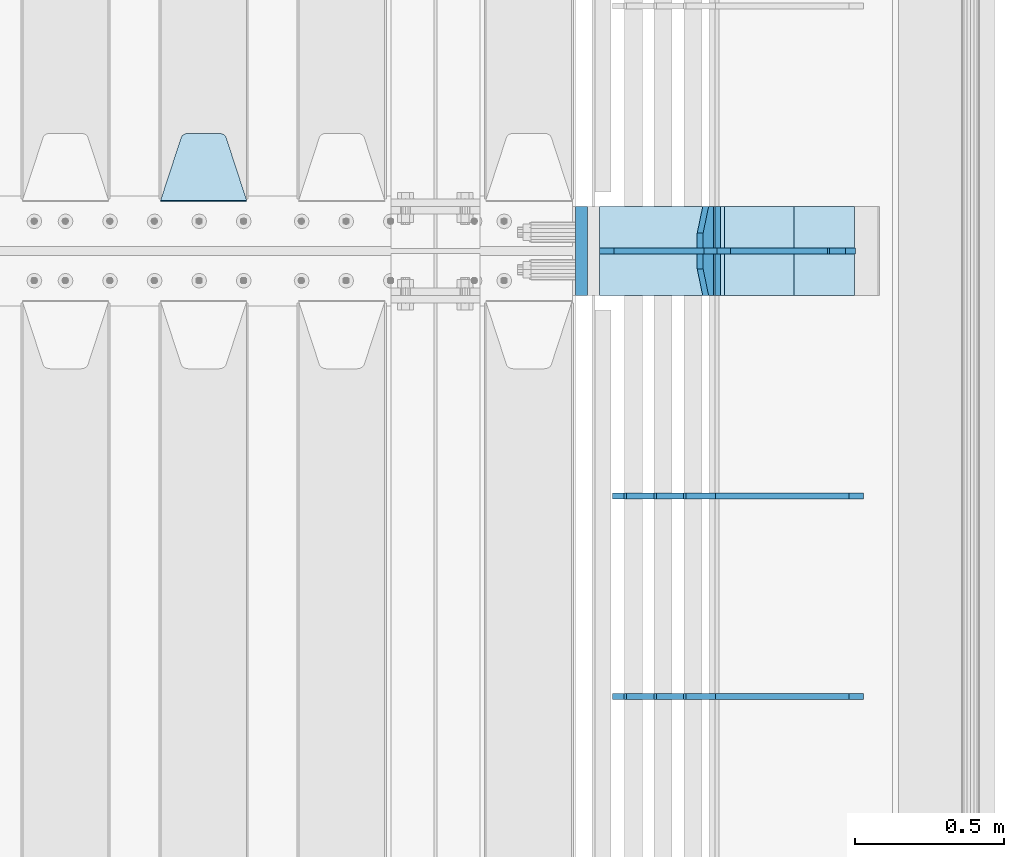
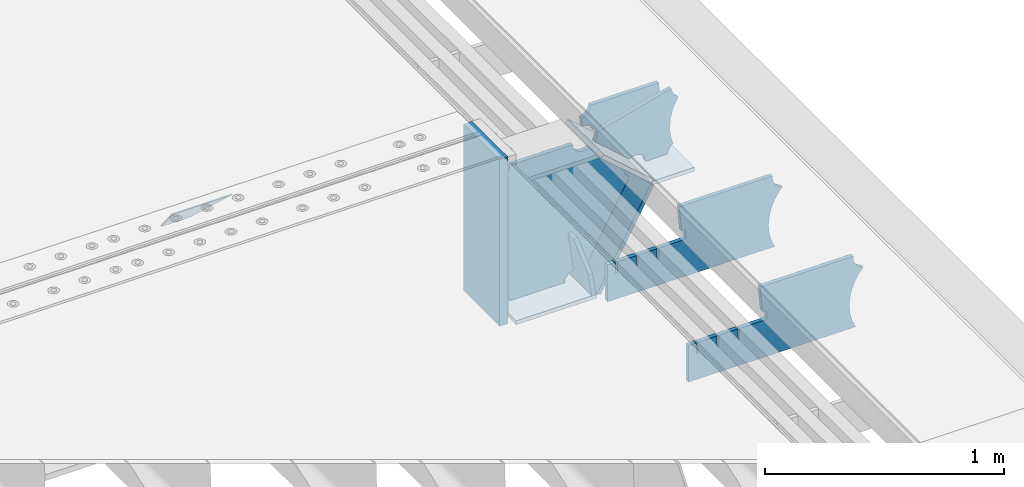
# One storey, part 236 of 257: 12 plates.
"""IFC2X3 building model written with IfcOpenShell, lengths in millimetres."""

from ifc_helpers import new_model, si_unit, frame, origin_with_axes, place, context, subcontext, project, spatial, faceted_brep, material, type_object, element, save


model = new_model("IFC2X3")

# Units and contexts
model_context = context("Model", 3, precision=1e-05, world=origin_with_axes())
body_context = subcontext(model_context, "Body", "Model", "MODEL_VIEW")
ifc_project = project(units=[si_unit("LENGTHUNIT", "METRE", prefix="MILLI"), si_unit("AREAUNIT", "SQUARE_METRE"), si_unit("VOLUMEUNIT", "CUBIC_METRE"), si_unit("MASSUNIT", "GRAM", prefix="KILO"), si_unit("TIMEUNIT", "SECOND"), si_unit("PLANEANGLEUNIT", "RADIAN"), si_unit("SOLIDANGLEUNIT", "STERADIAN"), si_unit("THERMODYNAMICTEMPERATUREUNIT", "DEGREE_CELSIUS"), si_unit("LUMINOUSINTENSITYUNIT", "LUMEN")], contexts=[model_context])

# Site, building, storey
site_placement = place(None, origin_with_axes())
site = spatial("IfcSite", under=ifc_project, at=site_placement, CompositionType="ELEMENT")
building_placement = place(site_placement, origin_with_axes())
building = spatial("IfcBuilding", under=site, at=building_placement, Name="Standard", CompositionType="ELEMENT")
storey_placement = place(building_placement, origin_with_axes())
storey = spatial("IfcBuildingStorey", under=building, at=storey_placement, Name="Undefined", CompositionType="ELEMENT", Elevation=0.0)

# Plates
ifc_material_1 = material(Name="STEEL/S355N")
plate_type_1 = type_object("IfcPlateType", PredefinedType="NOTDEFINED")
plate_1_placement = place(storey_placement, frame((58160.0, 3168.23223304703, -1.76776695296758), z_axis=(0.0, 0.707106781186547, -0.707106781186548), x_axis=(-1.0, 0.0, 0.0)))
element("IfcPlate", 1, at=plate_1_placement, inside=storey, type_object=plate_type_1, material=ifc_material_1, context=body_context, shape_type="Brep", body=[
    faceted_brep([(0.0, -2.5, 0.0), (69.345504679477, -2.50000000000091, 300.17173142483), (69.345504679477, 2.5, 300.171731424831), (0.0, 2.5, 0.0), (70.927406119954, -2.50000000000091, 304.8974424154), (70.927406119954, 2.5, 304.8974424154), (73.3818627772271, -2.50000000000091, 309.234538108527), (73.3818627772271, 2.49999999999909, 309.234538108527), (76.6187032999587, -2.5, 313.023683126103), (76.6187032999587, 2.5, 313.023683126103), (80.5190132705029, -2.5, 316.125672595372), (80.5190132705029, 2.5, 316.125672595371), (84.9395038596849, -2.5, 318.426546230476), (84.9395038596849, 2.5, 318.426546230477), (89.7177759439219, -2.5, 319.841774983275), (89.7177759439219, 2.5, 319.841774983275), (94.6782862926484, -2.5, 320.319366455079), (94.6782862926484, 2.5, 320.319366455079), (195.321713707352, -2.5, 320.319366455079), (195.321713707352, 2.5, 320.319366455079), (200.282224056078, -2.5, 319.841774983275), (200.282224056078, 2.49999999999909, 319.841774983275), (205.060496140315, -2.5, 318.426546230476), (205.060496140315, 2.49999999999909, 318.426546230475), (209.480986729497, -2.5, 316.125672595371), (209.480986729497, 2.5, 316.125672595371), (213.381296700041, -2.50000000000091, 313.023683126102), (213.381296700041, 2.5, 313.023683126103), (216.618137222766, -2.50000000000091, 309.234538108527), (216.618137222766, 2.5, 309.234538108527), (219.072593880039, -2.5, 304.897442415399), (219.072593880039, 2.5, 304.897442415399), (220.654495320523, -2.50000000000091, 300.17173142483), (220.654495320523, 2.5, 300.171731424831), (290.0, -2.50000000000091, 0.0), (290.0, 2.5, 9.09494701772928e-13)], [[[0, 1, 2, 3]], [[1, 4, 5, 2]], [[4, 6, 7, 5]], [[6, 8, 9, 7]], [[8, 10, 11, 9]], [[10, 12, 13, 11]], [[12, 14, 15, 13]], [[14, 16, 17, 15]], [[16, 18, 19, 17]], [[18, 20, 21, 19]], [[20, 22, 23, 21]], [[22, 24, 25, 23]], [[24, 26, 27, 25]], [[26, 28, 29, 27]], [[28, 30, 31, 29]], [[30, 32, 33, 31]], [[32, 34, 35, 33]], [[34, 0, 3, 35]], [[5, 7, 9, 11, 13, 15, 17, 19, 21, 23, 25, 27, 29, 31, 33, 35, 3, 2]], [[34, 32, 30, 28, 26, 24, 22, 20, 18, 16, 14, 12, 10, 8, 6, 4, 1, 0]]]),
])
plate_type_2 = type_object("IfcPlateType", PredefinedType="NOTDEFINED")
plate_2_placement = place(storey_placement, frame((59721.0775331948, 3150.00000000169, -871.412303810021), z_axis=(0.0, -1.0, 0.0), x_axis=(-0.137902988002477, 0.0, 0.990445741017643)))
element("IfcPlate", 2, at=plate_2_placement, inside=storey, type_object=plate_type_2, material=ifc_material_1, context=body_context, shape_type="Brep", body=[
    faceted_brep([(0.0, -10.0, 0.0), (-2.00088834390044e-10, -10.0, 300.0), (-2.00088834390044e-10, 10.0, 300.0), (0.0, 10.0, 0.0), (114.999999999998, -10.0, 300.0), (115.0, 10.0, 300.0), (249.999999999998, -10.0, 210.0), (249.999999999998, 10.0, 210.0), (249.999999999998, -10.0, 90.0), (249.999999999998, 10.0, 90.0), (114.999999999998, -10.0, -1.10503606265411e-10), (115.0, 10.0, -1.10503606265411e-10)], [[[0, 1, 2, 3]], [[1, 4, 5, 2]], [[4, 6, 7, 5]], [[6, 8, 9, 7]], [[8, 10, 11, 9]], [[10, 0, 3, 11]], [[5, 7, 9, 11, 3, 2]], [[10, 8, 6, 4, 1, 0]]]),
])
plate_type_3 = type_object("IfcPlateType", PredefinedType="NOTDEFINED")
plate_3_placement = place(storey_placement, frame((59749.9988298915, 3000.00000000007, -179.999999999866), z_axis=(0.0, 0.0, -1.0), x_axis=(-1.0, 0.0, 0.0)))
element("IfcPlate", 3, at=plate_3_placement, inside=storey, type_object=plate_type_3, material=ifc_material_1, context=body_context, shape_type="Brep", body=[
    faceted_brep([(46.0258547361809, 10.0, 641.078828352491), (73.3015011075258, 10.0, 445.179898435806), (73.3015011075258, -10.0, 445.179898435806), (46.0258547361809, -10.0, 641.078828352491), (53.4925862871751, 10.0, 442.421838675757), (53.4925862871751, -10.0, 442.421838675757), (25.7820501124297, 10.0, 641.4442306713), (25.7820501124297, -10.0, 641.4442306713), (54.6652503111691, 10.0, 642.447174185377), (54.6652503111691, -10.0, 642.447174185377), (68.6036632070463, -10.0, 649.549150281387), (68.6036632070463, 10.0, 649.549150281387), (79.6652503111691, -10.0, 660.610737385511), (79.6652503111691, 10.0, 660.610737385511), (86.7672264071807, -10.0, 674.549150281387), (86.7672264071807, 10.0, 674.549150281387), (89.2144005924201, -10.0, 690.0), (89.2144005924201, 10.0, 690.0), (353.0, -10.0, 690.0), (353.0, 10.0, 690.0), (355.447174185239, -10.0, 674.549150281253), (355.447174185239, 10.0, 674.549150281253), (362.549150281251, -10.0, 660.610737385376), (362.549150281251, 10.0, 660.610737385376), (373.610737385374, -10.0, 649.549150281253), (373.610737385374, 10.0, 649.549150281253), (387.549150281251, -10.0, 642.447174185242), (387.549150281251, 10.0, 642.447174185242), (403.0, -10.0, 640.0), (403.0, 10.0, 640.0), (403.0, -10.0, 50.0), (403.0, 10.0, 50.0), (387.549150281251, -10.0, 47.5528258147577), (387.549150281251, 10.0, 47.5528258147577), (373.610737385374, -10.0, 40.4508497187474), (373.610737385374, 10.0, 40.4508497187474), (362.549150281251, -10.0, 29.3892626146236), (362.549150281251, 10.0, 29.3892626146236), (355.447174185239, -10.0, 15.4508497187474), (355.447174185239, 10.0, 15.4508497187474), (353.0, -10.0, 0.0), (353.0, 10.0, 0.0), (50.0, -10.0, 0.0), (50.0, 10.0, 0.0), (47.0349915316328, -10.0, 16.9620037619133), (47.0349915316328, 10.0, 16.9620037619133), (38.4916171352306, -10.0, 31.9123081320451), (38.4916171352306, 10.0, 31.9123081320451), (25.3831239081483, -10.0, 43.0778019479116), (25.3831239081483, 10.0, 43.0778019479116), (9.26418358741648, -10.0, 49.1342538608113), (9.26418358741648, 10.0, 49.1342538608113), (-7.95349204488593, -10.0, 49.363366622344), (-7.95349204488593, 10.0, 49.363366622344), (-24.2278808265401, -10.0, 43.7379673813837), (-24.2278808265401, 10.0, 43.7379673813837), (-37.6288347353475, -10.0, 32.9252303934259), (-37.6288347353475, 10.0, 32.9252303934259), (-210.371165264653, -10.0, 184.074769606574), (-210.371165264653, 10.0, 184.074769606574), (-202.382363280565, -10.0, 196.529747922069), (-202.382363280565, 10.0, 196.529747922069), (-198.388707244048, -10.0, 210.777489969227), (-198.388707244048, 10.0, 210.777489969227), (-198.73995746443, -10.0, 225.570193077959), (-198.73995746443, 10.0, 225.570193077959), (-203.40535180681, -10.0, 239.612327446012), (-203.40535180681, 10.0, 239.612327446012), (-211.976299808361, -10.0, 251.674097313455), (-211.976299808361, 10.0, 251.674097313455), (-223.702166612966, -10.0, 260.699145216992), (-223.702166612966, 10.0, 260.699145216992), (-9.29783338703419, -10.0, 646.300854783008), (-9.29783338703419, 10.0, 646.300854783008), (6.98069453598146, -10.0, 640.647282345602), (6.98069453598146, 10.0, 640.647282345602), (24.2117663163663, -10.0, 640.855891896051), (24.2117663163663, 10.0, 640.855891896051)], [[[0, 1, 2, 3]], [[4, 5, 2, 1]], [[6, 7, 5, 4]], [[8, 9, 10, 11]], [[11, 10, 12, 13]], [[13, 12, 14, 15]], [[15, 14, 16, 17]], [[18, 19, 17, 16]], [[18, 20, 21, 19]], [[20, 22, 23, 21]], [[22, 24, 25, 23]], [[24, 26, 27, 25]], [[26, 28, 29, 27]], [[28, 30, 31, 29]], [[30, 32, 33, 31]], [[32, 34, 35, 33]], [[34, 36, 37, 35]], [[36, 38, 39, 37]], [[38, 40, 41, 39]], [[40, 42, 43, 41]], [[42, 44, 45, 43]], [[44, 46, 47, 45]], [[46, 48, 49, 47]], [[48, 50, 51, 49]], [[50, 52, 53, 51]], [[52, 54, 55, 53]], [[54, 56, 57, 55]], [[56, 58, 59, 57]], [[58, 60, 61, 59]], [[60, 62, 63, 61]], [[62, 64, 65, 63]], [[64, 66, 67, 65]], [[66, 68, 69, 67]], [[68, 70, 71, 69]], [[70, 72, 73, 71]], [[72, 74, 75, 73]], [[74, 76, 77, 75]], [[1, 0, 8, 11, 13, 15, 17, 19, 21, 23, 25, 27, 29, 31, 33, 35, 37, 39, 41, 43, 45, 47, 49, 51, 53, 55, 57, 59, 61, 63, 65, 67, 69, 71, 73, 75, 77, 6, 4]], [[9, 8, 0, 3]], [[76, 74, 72, 70, 68, 66, 64, 62, 60, 58, 56, 54, 52, 50, 48, 46, 44, 42, 40, 38, 36, 34, 32, 30, 28, 26, 24, 22, 20, 18, 16, 14, 12, 10, 9, 3, 2, 5, 7]], [[77, 76, 7, 6]]]),
])
plate_type_4 = type_object("IfcPlateType", PredefinedType="NOTDEFINED")
plate_4_placement = place(storey_placement, frame((60285.9988298907, 3000.0, -9.99999999999716), z_axis=(0.0, 0.0, -1.0), x_axis=(-1.0, 0.0, 0.0)))
element("IfcPlate", 4, at=plate_4_placement, inside=storey, type_object=plate_type_4, material=ifc_material_1, context=body_context, shape_type="Brep", body=[
    faceted_brep([(164.157641141064, -10.0, 44.1844865875018), (486.71834084086, -10.0, 131.004562768382), (486.71834084086, 10.0, 131.004562768382), (164.157641141064, 10.0, 44.1844865875018), (492.179177700767, -10.0, 118.185717565315), (492.179177700767, 10.0, 118.185717565315), (500.965368826706, -10.0, 107.371542744776), (500.965368826706, 10.0, 107.371542744776), (512.394601349042, -10.0, 99.4018391429503), (512.394601349042, 10.0, 99.4018391429503), (525.579310641864, -10.0, 94.8955133209048), (525.579310641864, 10.0, 94.8955133209048), (539.495606295335, -10.0, 94.2025148824028), (539.495606295335, 10.0, 94.2025148824028), (543.504393704665, -10.0, 49.7974851175972), (543.504393704665, 10.0, 49.7974851175972), (529.167086307512, -10.0, 46.3176139481669), (529.167086307512, 10.0, 46.3176139481669), (516.469507120331, -10.0, 38.8049999196639), (516.469507120331, 10.0, 38.8049999196639), (506.517198234542, -10.0, 27.9137449599276), (506.517198234542, 10.0, 27.9137449599276), (500.17667886756, -10.0, 14.592119649441), (500.17667886756, 10.0, 14.592119649441), (498.0, -10.0, 0.0), (498.0, 10.0, 0.0), (170.0, -10.0, 0.0), (170.0, 10.0, 0.0), (169.632873911985, -10.0, 11.1663820622718), (169.632873911985, 10.0, 11.1663820622718), (168.533081313406, -10.0, 22.2845350637931), (168.533081313406, 10.0, 22.2845350637931), (166.705372351957, -10.0, 33.3064382514178), (166.705372351957, 10.0, 33.3064382514178)], [[[0, 1, 2, 3]], [[1, 4, 5, 2]], [[4, 6, 7, 5]], [[6, 8, 9, 7]], [[8, 10, 11, 9]], [[10, 12, 13, 11]], [[12, 14, 15, 13]], [[14, 16, 17, 15]], [[16, 18, 19, 17]], [[18, 20, 21, 19]], [[20, 22, 23, 21]], [[22, 24, 25, 23]], [[24, 26, 27, 25]], [[26, 28, 29, 27]], [[28, 30, 31, 29]], [[30, 32, 33, 31]], [[32, 0, 3, 33]], [[5, 7, 9, 11, 13, 15, 17, 19, 21, 23, 25, 27, 29, 31, 33, 3, 2]], [[32, 30, 28, 26, 24, 22, 20, 18, 16, 14, 12, 10, 8, 6, 4, 1, 0]]]),
])
plate_type_5 = type_object("IfcPlateType", PredefinedType="NOTDEFINED")
plate_5_placement = place(storey_placement, frame((60290.9988502514, 2999.99999999933, -28.9999913318487), z_axis=(0.260769276985653, 0.0, -0.965401151946889), x_axis=(-0.965401151946889, 0.0, -0.260769276985654)))
element("IfcPlate", 5, at=plate_5_placement, inside=storey, type_object=plate_type_5, material=ifc_material_1, context=body_context, shape_type="Brep", body=[
    faceted_brep([(183.436474692309, 10.0, 275.852500330426), (184.918388609047, 10.0, 264.417843531332), (184.918388609047, -10.0, 264.417843531332), (183.436474692309, -10.0, 275.852500330426), (183.794583267605, 10.0, 224.576469334614), (183.794583267605, -10.0, 224.576469334614), (176.452049775828, 10.0, 185.401410454628), (176.452049775828, -10.0, 185.401410454628), (163.071585676764, 10.0, 147.857286855564), (163.071585676764, -10.0, 147.857286855564), (143.982662403738, 10.0, 112.868559462235), (143.982662403738, -10.0, 112.868559462235), (119.65531260024, 10.0, 81.2967668639885), (119.65531260024, -10.0, 81.2967668639885), (100.960891712741, 10.0, 63.6280409830997), (100.960891712741, -10.0, 63.6280409830997), (194.486836975899, -10.0, 278.751956446691), (207.178624553366, -10.0, 286.65099493752), (207.178624553366, 10.0, 286.65099493752), (194.486836975899, 10.0, 278.751956446691), (216.968013469435, -10.0, 297.948965801401), (216.968013469435, 10.0, 297.948965801401), (222.979925232852, -10.0, 311.635937633771), (222.979925232852, 10.0, 311.635937633771), (323.381647032758, -10.0, 284.515917834988), (323.381647032758, 10.0, 284.515917834988), (321.720617177329, -10.0, 268.853198956864), (321.720617177329, 10.0, 268.853198956864), (325.01434448114, -10.0, 253.450889283185), (325.01434448114, 10.0, 253.450889283185), (332.935986082477, -10.0, 239.837389469556), (332.935986082477, 10.0, 239.837389469556), (344.699462330085, -10.0, 229.36359314694), (344.699462330085, 10.0, 229.36359314694), (359.1374609708, -10.0, 223.068835162203), (359.1374609708, 10.0, 223.068835162203), (374.817271777676, -10.0, 221.577756392893), (374.817271777676, 10.0, 221.577756392893), (390.182952880852, -10.0, 225.03833007813), (390.182952880852, 10.0, 225.03833007813), (512.909060513019, -10.0, 41.5599003357038), (512.909060513019, 10.0, 41.5599003357038), (503.648024844573, -10.0, 33.5643666747728), (503.648024844573, 10.0, 33.5643666747728), (496.6060645697, -10.0, 23.5590612990018), (496.6060645697, 10.0, 23.5590612990018), (492.204839143924, -10.0, 12.1430832451115), (492.204839143924, 10.0, 12.1430832451115), (490.707885742188, -10.0, 3.83806764148176e-10), (490.707885742188, 10.0, 3.83806764148176e-10), (119.999999999993, -10.0, 9.64064383879304e-11), (119.999999999993, 10.0, 9.64064383879304e-11), (117.226254779103, -10.0, 25.6516118492182), (117.226254779103, 10.0, 25.6516118492182), (109.033246825653, -10.0, 50.1173731021008), (109.033246825653, 10.0, 50.1173731021008)], [[[0, 1, 2, 3]], [[4, 5, 2, 1]], [[6, 7, 5, 4]], [[8, 9, 7, 6]], [[10, 11, 9, 8]], [[12, 13, 11, 10]], [[14, 15, 13, 12]], [[16, 17, 18, 19]], [[17, 20, 21, 18]], [[20, 22, 23, 21]], [[22, 24, 25, 23]], [[24, 26, 27, 25]], [[26, 28, 29, 27]], [[28, 30, 31, 29]], [[30, 32, 33, 31]], [[32, 34, 35, 33]], [[34, 36, 37, 35]], [[36, 38, 39, 37]], [[38, 40, 41, 39]], [[40, 42, 43, 41]], [[42, 44, 45, 43]], [[44, 46, 47, 45]], [[46, 48, 49, 47]], [[48, 50, 51, 49]], [[50, 52, 53, 51]], [[52, 54, 55, 53]], [[10, 8, 6, 4, 1, 0, 19, 18, 21, 23, 25, 27, 29, 31, 33, 35, 37, 39, 41, 43, 45, 47, 49, 51, 53, 55, 14, 12]], [[16, 19, 0, 3]], [[54, 52, 50, 48, 46, 44, 42, 40, 38, 36, 34, 32, 30, 28, 26, 24, 22, 20, 17, 16, 3, 2, 5, 7, 9, 11, 13, 15]], [[55, 54, 15, 14]]]),
])
plate_type_6 = type_object("IfcPlateType", PredefinedType="NOTDEFINED")
plate_6_placement = place(storey_placement, frame((59762.2260590444, 3149.99999999933, -177.219372761326), z_axis=(0.752414935148685, 0.0, -0.658689430130164), x_axis=(0.0, -1.0, 0.0)))
element("IfcPlate", 6, at=plate_6_placement, inside=storey, type_object=plate_type_6, material=ifc_material_1, context=body_context, shape_type="Brep", body=[
    faceted_brep([(0.0, -10.0, 0.0), (1.09139364212751e-10, -10.0000000000146, 319.999999999993), (1.09139364212751e-10, 9.99999999999272, 320.0), (0.0, 10.0, 0.0), (300.0, -10.0000000000146, 319.999999999993), (300.0, 9.99999999999272, 320.0), (300.0, -10.0000000000073, 5.82076609134674e-11), (300.0, 9.99999999999272, 5.82076609134674e-11)], [[[0, 1, 2, 3]], [[1, 4, 5, 2]], [[4, 6, 7, 5]], [[6, 0, 3, 7]], [[5, 7, 3, 2]], [[6, 4, 1, 0]]]),
])
plate_7_placement = place(storey_placement, frame((60003.000728811, 3150.00000000007, -408.004820491625), z_axis=(-0.484064236150485, 0.0, -0.875032465272031), x_axis=(0.0, -1.0, 0.0)))
element("IfcPlate", 7, at=plate_7_placement, inside=storey, type_object=plate_type_6, material=ifc_material_1, context=body_context, shape_type="Brep", body=[
    faceted_brep([(0.0, -10.0, 0.0), (3.86515239370056e-07, -10.0, 533.528442382816), (3.86515239370056e-07, 10.0, 533.528442382813), (0.0, 10.0, 0.0), (300.003295898438, -10.0, 533.549133300781), (300.003295898438, 10.0, 533.549133300785), (300.0, -10.0000000000073, 5.82076609134674e-11), (300.0, 9.99999999999272, 5.82076609134674e-11)], [[[0, 1, 2, 3]], [[1, 4, 5, 2]], [[4, 6, 7, 5]], [[6, 0, 3, 7]], [[5, 7, 3, 2]], [[6, 4, 1, 0]]]),
])
plate_8_placement = place(storey_placement, frame((59346.9988298915, 3150.00000000007, -879.999999999866), z_axis=(0.0, -1.0, 0.0), x_axis=(1.0, 0.0, 0.0)))
element("IfcPlate", 8, at=plate_8_placement, inside=storey, type_object=plate_type_6, material=ifc_material_1, context=body_context, shape_type="Brep", body=[
    faceted_brep([(0.0, -10.0, 0.0), (-2.00088834390044e-10, -10.0, 300.0), (-2.00088834390044e-10, 10.0, 300.0), (0.0, 10.0, 0.0), (389.0, -10.0, 300.0), (389.0, 10.0, 300.0), (389.0, -10.0, 0.0), (389.0, 10.0, 0.0)], [[[0, 1, 2, 3]], [[1, 4, 5, 2]], [[4, 6, 7, 5]], [[6, 0, 3, 7]], [[5, 7, 3, 2]], [[6, 4, 1, 0]]]),
])
plate_type_7 = type_object("IfcPlateType", PredefinedType="NOTDEFINED")
plate_9_placement = place(storey_placement, frame((60206.9988298915, 3149.99999999933, -397.999999999763), z_axis=(-1.0, 0.0, 0.0), x_axis=(0.0, -1.0, 0.0)))
element("IfcPlate", 9, at=plate_9_placement, inside=storey, type_object=plate_type_7, material=ifc_material_1, context=body_context, shape_type="Brep", body=[
    faceted_brep([(0.0, -10.0, 0.0), (4.63842297904193e-10, -10.0, 204.0), (4.63842297904193e-10, 10.0, 204.0), (0.0, 10.0, 0.0), (300.0, -10.0, 204.0), (300.0, 10.0, 204.0), (300.0, -10.0000000000073, 5.82076609134674e-11), (300.0, 9.99999999999272, 5.82076609134674e-11)], [[[0, 1, 2, 3]], [[1, 4, 5, 2]], [[4, 6, 7, 5]], [[6, 0, 3, 7]], [[5, 7, 3, 2]], [[6, 4, 1, 0]]]),
])
ifc_material_2 = material()
plate_type_8 = type_object("IfcPlateType", PredefinedType="NOTDEFINED")
plate_10_placement = place(storey_placement, frame((59287.0, 3150.0, -870.0), z_axis=(0.0, 0.0, 1.0), x_axis=(0.0, -1.0, 0.0)))
element("IfcPlate", 10, at=plate_10_placement, inside=storey, type_object=plate_type_8, material=ifc_material_2, context=body_context, shape_type="Brep", body=[
    faceted_brep([(0.0, -20.0, 0.0), (0.0, -20.0, 850.0), (0.0, 20.0, 850.0), (0.0, 20.0, 0.0), (300.0, -20.0, 850.0), (300.0, 20.0, 850.0), (300.0, -20.0, -1.81898940354586e-12), (300.0, 20.0, -1.81898940354586e-12)], [[[0, 1, 2, 3]], [[1, 4, 5, 2]], [[4, 6, 7, 5]], [[6, 0, 3, 7]], [[5, 7, 3, 2]], [[6, 4, 1, 0]]]),
])
plate_type_9 = type_object("IfcPlateType", PredefinedType="NOTDEFINED")
plate_11_placement = place(storey_placement, frame((60232.9182339676, 1499.99928283691, -374.002067436518), z_axis=(0.0, 0.0, 1.0), x_axis=(-1.0, 0.0, 0.0)))
element("IfcPlate", 11, at=plate_11_placement, inside=storey, type_object=plate_type_9, material=ifc_material_1, context=body_context, shape_type="Brep", body=[
    faceted_brep([(801.919404066546, -10.0, 188.0), (801.919404066546, 10.0, 188.0), (801.919404066546, 10.0, 132.002067436952), (801.919404066546, -10.0, 132.002067436952), (793.919404066546, 10.0, 132.002067436952), (793.919404066546, -10.0, 132.002067436952), (793.919404066546, 10.0, 180.002067436952), (793.919404066546, -10.0, 180.002067436952), (793.52785619691, 10.0, 182.474203391951), (793.52785619691, -10.0, 182.474203391951), (792.391540021548, 10.0, 184.704349455291), (792.391540021548, -10.0, 184.704349455291), (790.621686084887, 10.0, 186.474203391951), (790.621686084887, -10.0, 186.474203391951), (788.391540021548, 10.0, 187.610519567313), (788.391540021548, -10.0, 187.610519567313), (785.919404066546, -10.0, 188.002067436952), (785.919404066546, 10.0, 188.0), (841.0, -10.0, 188.0), (841.0, -10.0, 0.0), (841.0, 10.0, 0.0), (841.0, 10.0, 188.0), (33.3619566735943, -10.0, 0.0), (33.3619566735943, 10.0, 0.0), (36.2350612208102, -10.0, 4.68848050267013), (36.2350612208102, 10.0, 4.68848050267013), (51.4877592159319, -10.0, 41.5117508652784), (51.4877592159319, 10.0, 41.5117508652784), (60.7922425881334, -10.0, 80.2677133162964), (60.7922425881334, 10.0, 80.2677133162964), (63.9194040769653, -10.0, 120.002067436515), (63.9194040769653, 10.0, 120.002067436515), (60.7922425881334, -10.0, 159.736421556734), (60.7922425881334, 10.0, 159.736421556734), (51.4877592159319, -10.0, 198.492384007752), (51.4877592159319, 10.0, 198.492384007752), (36.2350612208102, -10.0, 235.31565437036), (36.2350612208102, 10.0, 235.31565437036), (15.4097206482038, -10.0, 269.299521518803), (15.4097206482038, 10.0, 269.299521518803), (-3.35474438100209, -10.0, 291.269887256574), (-3.35474438100209, 10.0, 291.269887256574), (-2.36881039375294, -10.0000000000001, 291.426043859339), (-2.36881039375294, 10.0, 291.426043859339), (17.1449676604752, -10.0000000000001, 301.368810393754), (17.1449676604752, 10.0, 301.368810393754), (32.6311896062471, -10.0000000000001, 316.855032339527), (32.6311896062471, 10.0, 316.855032339527), (42.573956140659, -10.0000000000001, 336.368810393754), (42.573956140659, 10.0, 336.368810393754), (46.0, -10.0000000000001, 358.0), (46.0, 10.0, 358.0), (45.0495205499174, -10.0, 364.001091067617), (45.0495205499174, 10.0, 364.001091067617), (495.040008544922, -10.0, 364.010009765625), (495.040008544922, 10.0, 364.010009765625), (483.600036621094, -10.0, 233.759994506836), (483.600036621094, 10.0, 233.759994506836), (472.0, -10.0, 233.759994506836), (472.0, 10.0, 233.759994506836), (468.909830056247, -10.0, 233.270559669787), (468.909830056247, 10.0, 233.270559669787), (466.122147477072, -10.0, 231.850164450585), (466.122147477072, 10.0, 231.850164450585), (463.909830056247, -10.0, 229.637847029761), (463.909830056247, 10.0, 229.637847029761), (462.489434837051, -10.0, 226.850164450585), (462.489434837051, 10.0, 226.850164450585), (462.0, -10.0, 223.759994506836), (462.0, 10.0, 223.759994506836), (462.0, -10.0, 198.0), (462.0, 10.0, 198.0), (462.489434837051, -10.0, 194.909830056251), (462.489434837051, 10.0, 194.909830056251), (463.909830056247, -10.0, 192.122147477075), (463.909830056247, 10.0, 192.122147477075), (466.122147477072, -10.0, 189.909830056251), (466.122147477072, 10.0, 189.909830056251), (468.909830056247, -10.0, 188.489434837048), (468.909830056247, 10.0, 188.489434837048), (472.0, -10.0, 188.0), (472.0, 10.0, 188.0), (585.919404066546, -10.0, 188.002067436952), (585.919404066546, 10.0, 188.0), (588.391540021548, -10.0, 187.610519567313), (588.391540021548, 10.0, 187.610519567313), (590.621686084887, -10.0, 186.474203391951), (590.621686084887, 10.0, 186.474203391951), (592.391540021548, -10.0, 184.704349455291), (592.391540021548, 10.0, 184.704349455291), (593.52785619691, -10.0, 182.474203391951), (593.52785619691, 10.0, 182.474203391951), (593.919404066546, -10.0, 180.002067436952), (593.919404066546, 10.0, 180.002067436952), (593.919404066546, -10.0, 132.002067436952), (593.919404066546, 10.0, 132.002067436952), (601.919404066546, -10.0, 132.002067436952), (601.919404066546, 10.0, 132.002067436952), (601.919404066546, -10.0, 188.0), (601.919404066546, 10.0, 188.0), (685.919404066546, -10.0, 188.002067436952), (685.919404066546, 10.0, 188.0), (688.391540021548, -9.99999999999977, 187.610519567313), (688.391540021548, 10.0, 187.610519567313), (690.621686084887, -9.99999999999977, 186.474203391951), (690.621686084887, 10.0, 186.474203391951), (692.391540021548, -9.99999999999977, 184.704349455291), (692.391540021548, 10.0, 184.704349455291), (693.52785619691, -9.99999999999977, 182.474203391951), (693.52785619691, 10.0, 182.474203391951), (693.919404066546, -9.99999999999977, 180.002067436952), (693.919404066546, 10.0, 180.002067436952), (693.919404066546, -9.99999999999977, 132.002067436952), (693.919404066546, 10.0, 132.002067436952), (701.919404066546, -9.99999999999977, 132.002067436952), (701.919404066546, 10.0, 132.002067436952), (701.919404066546, -10.0, 188.0), (701.919404066546, 10.0, 188.0)], [[[0, 1, 2, 3]], [[3, 2, 4, 5]], [[5, 4, 6, 7]], [[7, 6, 8, 9]], [[9, 8, 10, 11]], [[11, 10, 12, 13]], [[13, 12, 14, 15]], [[16, 15, 14, 17]], [[18, 19, 20, 21]], [[20, 19, 22, 23]], [[22, 24, 25, 23]], [[26, 27, 25, 24]], [[28, 29, 27, 26]], [[30, 31, 29, 28]], [[32, 33, 31, 30]], [[34, 35, 33, 32]], [[36, 37, 35, 34]], [[38, 39, 37, 36]], [[39, 38, 40, 41]], [[40, 42, 43, 41]], [[44, 45, 43, 42]], [[46, 47, 45, 44]], [[48, 49, 47, 46]], [[50, 51, 49, 48]], [[52, 53, 51, 50]], [[54, 55, 53, 52]], [[54, 56, 57, 55]], [[56, 58, 59, 57]], [[58, 60, 61, 59]], [[60, 62, 63, 61]], [[62, 64, 65, 63]], [[64, 66, 67, 65]], [[66, 68, 69, 67]], [[68, 70, 71, 69]], [[70, 72, 73, 71]], [[72, 74, 75, 73]], [[74, 76, 77, 75]], [[76, 78, 79, 77]], [[78, 80, 81, 79]], [[81, 80, 82, 83]], [[82, 84, 85, 83]], [[86, 87, 85, 84]], [[88, 89, 87, 86]], [[90, 91, 89, 88]], [[92, 93, 91, 90]], [[94, 95, 93, 92]], [[96, 97, 95, 94]], [[98, 99, 97, 96]], [[99, 98, 100, 101]], [[100, 102, 103, 101]], [[104, 105, 103, 102]], [[106, 107, 105, 104]], [[108, 109, 107, 106]], [[110, 111, 109, 108]], [[112, 113, 111, 110]], [[114, 115, 113, 112]], [[116, 117, 115, 114]], [[117, 116, 16, 17]], [[12, 10, 8, 6, 4, 2, 1, 21, 20, 23, 25, 27, 29, 31, 33, 35, 37, 39, 41, 43, 45, 47, 49, 51, 53, 55, 57, 59, 61, 63, 65, 67, 69, 71, 73, 75, 77, 79, 81, 83, 85, 87, 89, 91, 93, 95, 97, 99, 101, 103, 105, 107, 109, 111, 113, 115, 117, 17, 14]], [[18, 21, 1, 0]], [[116, 114, 112, 110, 108, 106, 104, 102, 100, 98, 96, 94, 92, 90, 88, 86, 84, 82, 80, 78, 76, 74, 72, 70, 68, 66, 64, 62, 60, 58, 56, 54, 52, 50, 48, 46, 44, 42, 40, 38, 36, 34, 32, 30, 28, 26, 24, 22, 19, 18, 0, 3, 5, 7, 9, 11, 13, 15, 16]]]),
])
plate_12_placement = place(storey_placement, frame((60232.9182339676, 2174.99928283691, -374.002067436518), z_axis=(0.0, 0.0, 1.0), x_axis=(-1.0, 0.0, 0.0)))
element("IfcPlate", 12, at=plate_12_placement, inside=storey, type_object=plate_type_9, material=ifc_material_1, context=body_context, shape_type="Brep", body=[
    faceted_brep([(801.919404066546, -10.0, 188.0), (801.919404066546, 10.0, 188.0), (801.919404066546, 10.0, 132.002067436952), (801.919404066546, -10.0, 132.002067436952), (793.919404066546, 10.0, 132.002067436952), (793.919404066546, -10.0, 132.002067436952), (793.919404066546, 10.0, 180.002067436952), (793.919404066546, -10.0, 180.002067436952), (793.52785619691, 10.0, 182.474203391951), (793.52785619691, -10.0, 182.474203391951), (792.391540021548, 10.0, 184.704349455291), (792.391540021548, -10.0, 184.704349455291), (790.621686084887, 10.0, 186.474203391951), (790.621686084887, -10.0, 186.474203391951), (788.391540021548, 10.0, 187.610519567313), (788.391540021548, -10.0, 187.610519567313), (785.919404066546, -10.0, 188.002067436952), (785.919404066546, 10.0, 188.0), (841.0, -10.0, 188.0), (841.0, -10.0, 0.0), (841.0, 10.0, 0.0), (841.0, 10.0, 188.0), (33.3619566735943, -10.0, 0.0), (33.3619566735943, 10.0, 0.0), (36.2350612208102, -10.0, 4.68848050267013), (36.2350612208102, 10.0, 4.68848050267013), (51.4877592159319, -10.0, 41.5117508652784), (51.4877592159319, 10.0, 41.5117508652784), (60.7922425881334, -10.0, 80.2677133162964), (60.7922425881334, 10.0, 80.2677133162964), (63.9194040769653, -10.0, 120.002067436515), (63.9194040769653, 10.0, 120.002067436515), (60.7922425881334, -10.0, 159.736421556734), (60.7922425881334, 10.0, 159.736421556734), (51.4877592159319, -10.0, 198.492384007752), (51.4877592159319, 10.0, 198.492384007752), (36.2350612208102, -10.0, 235.31565437036), (36.2350612208102, 10.0, 235.31565437036), (15.4097206482038, -10.0, 269.299521518803), (15.4097206482038, 10.0, 269.299521518803), (-3.35474438100209, -10.0, 291.269887256574), (-3.35474438100209, 10.0, 291.269887256574), (-2.36881039375294, -10.0000000000001, 291.426043859339), (-2.36881039375294, 10.0, 291.426043859339), (17.1449676604752, -10.0000000000001, 301.368810393754), (17.1449676604752, 10.0, 301.368810393754), (32.6311896062471, -10.0000000000001, 316.855032339527), (32.6311896062471, 10.0, 316.855032339527), (42.573956140659, -10.0000000000001, 336.368810393754), (42.573956140659, 10.0, 336.368810393754), (46.0, -10.0000000000001, 358.0), (46.0, 10.0, 358.0), (45.0495205499174, -10.0, 364.001091067617), (45.0495205499174, 10.0, 364.001091067617), (495.040008544922, -10.0, 364.010009765625), (495.040008544922, 10.0, 364.010009765625), (483.600036621094, -10.0, 233.759994506836), (483.600036621094, 10.0, 233.759994506836), (472.0, -10.0, 233.759994506836), (472.0, 10.0, 233.759994506836), (468.909830056247, -10.0, 233.270559669787), (468.909830056247, 10.0, 233.270559669787), (466.122147477072, -10.0, 231.850164450585), (466.122147477072, 10.0, 231.850164450585), (463.909830056247, -10.0, 229.637847029761), (463.909830056247, 10.0, 229.637847029761), (462.489434837051, -10.0, 226.850164450585), (462.489434837051, 10.0, 226.850164450585), (462.0, -10.0, 223.759994506836), (462.0, 10.0, 223.759994506836), (462.0, -10.0, 198.0), (462.0, 10.0, 198.0), (462.489434837051, -10.0, 194.909830056251), (462.489434837051, 10.0, 194.909830056251), (463.909830056247, -10.0, 192.122147477075), (463.909830056247, 10.0, 192.122147477075), (466.122147477072, -10.0, 189.909830056251), (466.122147477072, 10.0, 189.909830056251), (468.909830056247, -10.0, 188.489434837048), (468.909830056247, 10.0, 188.489434837048), (472.0, -10.0, 188.0), (472.0, 10.0, 188.0), (585.919404066546, -10.0, 188.002067436952), (585.919404066546, 10.0, 188.0), (588.391540021548, -10.0, 187.610519567313), (588.391540021548, 10.0, 187.610519567313), (590.621686084887, -10.0, 186.474203391951), (590.621686084887, 10.0, 186.474203391951), (592.391540021548, -10.0, 184.704349455291), (592.391540021548, 10.0, 184.704349455291), (593.52785619691, -10.0, 182.474203391951), (593.52785619691, 10.0, 182.474203391951), (593.919404066546, -10.0, 180.002067436952), (593.919404066546, 10.0, 180.002067436952), (593.919404066546, -10.0, 132.002067436952), (593.919404066546, 10.0, 132.002067436952), (601.919404066546, -10.0, 132.002067436952), (601.919404066546, 10.0, 132.002067436952), (601.919404066546, -10.0, 188.0), (601.919404066546, 10.0, 188.0), (685.919404066546, -10.0, 188.002067436952), (685.919404066546, 10.0, 188.0), (688.391540021548, -9.99999999999977, 187.610519567313), (688.391540021548, 10.0, 187.610519567313), (690.621686084887, -9.99999999999977, 186.474203391951), (690.621686084887, 10.0, 186.474203391951), (692.391540021548, -9.99999999999977, 184.704349455291), (692.391540021548, 10.0, 184.704349455291), (693.52785619691, -9.99999999999977, 182.474203391951), (693.52785619691, 10.0, 182.474203391951), (693.919404066546, -9.99999999999977, 180.002067436952), (693.919404066546, 10.0, 180.002067436952), (693.919404066546, -9.99999999999977, 132.002067436952), (693.919404066546, 10.0, 132.002067436952), (701.919404066546, -9.99999999999977, 132.002067436952), (701.919404066546, 10.0, 132.002067436952), (701.919404066546, -10.0, 188.0), (701.919404066546, 10.0, 188.0)], [[[0, 1, 2, 3]], [[3, 2, 4, 5]], [[5, 4, 6, 7]], [[7, 6, 8, 9]], [[9, 8, 10, 11]], [[11, 10, 12, 13]], [[13, 12, 14, 15]], [[16, 15, 14, 17]], [[18, 19, 20, 21]], [[20, 19, 22, 23]], [[22, 24, 25, 23]], [[26, 27, 25, 24]], [[28, 29, 27, 26]], [[30, 31, 29, 28]], [[32, 33, 31, 30]], [[34, 35, 33, 32]], [[36, 37, 35, 34]], [[38, 39, 37, 36]], [[39, 38, 40, 41]], [[40, 42, 43, 41]], [[44, 45, 43, 42]], [[46, 47, 45, 44]], [[48, 49, 47, 46]], [[50, 51, 49, 48]], [[52, 53, 51, 50]], [[54, 55, 53, 52]], [[54, 56, 57, 55]], [[56, 58, 59, 57]], [[58, 60, 61, 59]], [[60, 62, 63, 61]], [[62, 64, 65, 63]], [[64, 66, 67, 65]], [[66, 68, 69, 67]], [[68, 70, 71, 69]], [[70, 72, 73, 71]], [[72, 74, 75, 73]], [[74, 76, 77, 75]], [[76, 78, 79, 77]], [[78, 80, 81, 79]], [[81, 80, 82, 83]], [[82, 84, 85, 83]], [[86, 87, 85, 84]], [[88, 89, 87, 86]], [[90, 91, 89, 88]], [[92, 93, 91, 90]], [[94, 95, 93, 92]], [[96, 97, 95, 94]], [[98, 99, 97, 96]], [[99, 98, 100, 101]], [[100, 102, 103, 101]], [[104, 105, 103, 102]], [[106, 107, 105, 104]], [[108, 109, 107, 106]], [[110, 111, 109, 108]], [[112, 113, 111, 110]], [[114, 115, 113, 112]], [[116, 117, 115, 114]], [[117, 116, 16, 17]], [[12, 10, 8, 6, 4, 2, 1, 21, 20, 23, 25, 27, 29, 31, 33, 35, 37, 39, 41, 43, 45, 47, 49, 51, 53, 55, 57, 59, 61, 63, 65, 67, 69, 71, 73, 75, 77, 79, 81, 83, 85, 87, 89, 91, 93, 95, 97, 99, 101, 103, 105, 107, 109, 111, 113, 115, 117, 17, 14]], [[18, 21, 1, 0]], [[116, 114, 112, 110, 108, 106, 104, 102, 100, 98, 96, 94, 92, 90, 88, 86, 84, 82, 80, 78, 76, 74, 72, 70, 68, 66, 64, 62, 60, 58, 56, 54, 52, 50, 48, 46, 44, 42, 40, 38, 36, 34, 32, 30, 28, 26, 24, 22, 19, 18, 0, 3, 5, 7, 9, 11, 13, 15, 16]]]),
])

save(model, "model.ifc")
